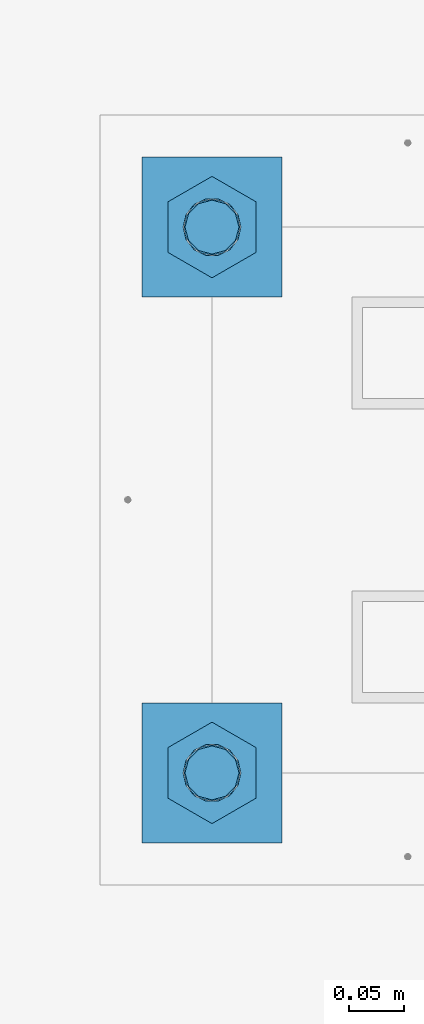
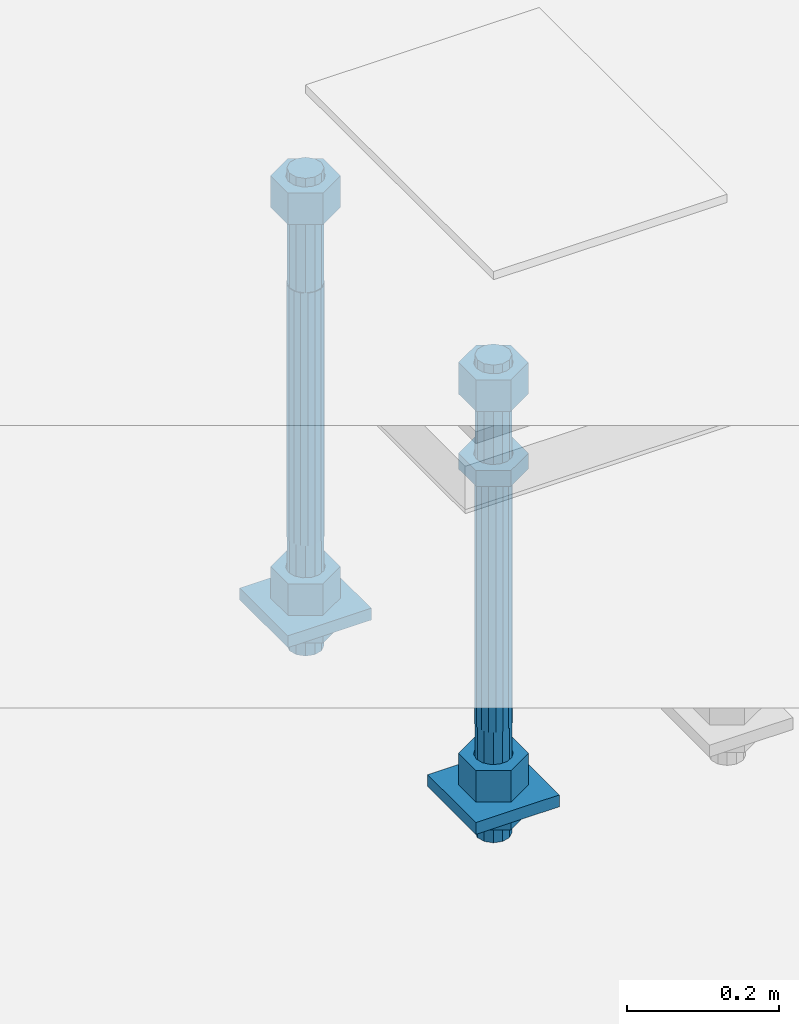
# One storey, part 2620 of 3843: 11 beams, 1 element without a shape of its own.
"""IFC2X3 building model written with IfcOpenShell, lengths in millimetres."""

from ifc_helpers import new_model, si_unit, frame, origin_with_axes, place, context, subcontext, project, spatial, faceted_brep, material, type_object, element, aggregate, save


model = new_model("IFC2X3")

# Units and contexts
model_context = context("Model", 3, precision=1e-05, world=origin_with_axes())
body_context = subcontext(model_context, "Body", "Model", "MODEL_VIEW")
ifc_project = project(units=[si_unit("LENGTHUNIT", "METRE", prefix="MILLI"), si_unit("AREAUNIT", "SQUARE_METRE"), si_unit("VOLUMEUNIT", "CUBIC_METRE"), si_unit("MASSUNIT", "GRAM", prefix="KILO"), si_unit("TIMEUNIT", "SECOND"), si_unit("PLANEANGLEUNIT", "RADIAN"), si_unit("SOLIDANGLEUNIT", "STERADIAN"), si_unit("THERMODYNAMICTEMPERATUREUNIT", "DEGREE_CELSIUS"), si_unit("LUMINOUSINTENSITYUNIT", "LUMEN")], contexts=[model_context])

# Site, building, storey
site_placement = place(None, origin_with_axes())
site = spatial("IfcSite", under=ifc_project, at=site_placement, CompositionType="ELEMENT")
building_placement = place(site_placement, origin_with_axes())
building = spatial("IfcBuilding", under=site, at=building_placement, Name="Undefined", CompositionType="ELEMENT")
storey_placement = place(building_placement, origin_with_axes())
storey = spatial("IfcBuildingStorey", under=building, at=storey_placement, Name="Undefined", CompositionType="ELEMENT", Elevation=0.0)

# Assembly, beams
assembly_placement = place(storey_placement, origin_with_axes())
assembly = element("IfcElementAssembly", 1, at=assembly_placement, inside=storey, Name="TEMPLATE", AssemblyPlace="NOTDEFINED", PredefinedType="RIGID_FRAME")
ifc_material_1 = material(Name="STEEL/A572-50")
beam_type_1 = type_object("IfcBeamType", PredefinedType="NOTDEFINED")
beam_1_placement = place(assembly_placement, frame((115862.100001526, 247.649999999994, 29244.925), z_axis=(0.0, -1.0, 0.0), x_axis=(1.0, 0.0, 0.0)))
beam_1 = element("IfcBeam", 2, at=beam_1_placement, type_object=beam_type_1, material=ifc_material_1, Name="WASHER_PLATE", context=body_context, shape_type="Brep", body=[
    faceted_brep([(0.0, 9.52500000000146, -63.5), (0.0, 9.52500000000146, 63.5), (127.0, 9.52500000000146, 63.5), (127.0, 9.52500000000146, -63.5), (0.0, -9.52500000000146, 63.5), (127.0, -9.52500000000146, 63.5), (0.0, -9.52500000000146, -63.5), (127.0, -9.52500000000146, -63.5)], [[[0, 1, 2, 3]], [[1, 4, 5, 2]], [[4, 6, 7, 5]], [[6, 0, 3, 7]], [[5, 7, 3, 2]], [[6, 4, 1, 0]]]),
])
beam_2_placement = place(assembly_placement, frame((115862.100001526, -247.649999999994, 29244.925), z_axis=(0.0, -1.0, 0.0), x_axis=(1.0, 0.0, 0.0)))
beam_2 = element("IfcBeam", 3, at=beam_2_placement, type_object=beam_type_1, material=ifc_material_1, Name="WASHER_PLATE", context=body_context, shape_type="Brep", body=[
    faceted_brep([(0.0, 9.52500000000146, -63.5), (0.0, 9.52500000000146, 63.5), (127.0, 9.52500000000146, 63.5), (127.0, 9.52500000000146, -63.5), (0.0, -9.52500000000146, 63.5), (127.0, -9.52500000000146, 63.5), (0.0, -9.52500000000146, -63.5), (127.0, -9.52500000000146, -63.5)], [[[0, 1, 2, 3]], [[1, 4, 5, 2]], [[4, 6, 7, 5]], [[6, 0, 3, 7]], [[5, 7, 3, 2]], [[6, 4, 1, 0]]]),
])
ifc_material_2 = material(Name="STEEL/A36")
beam_type_2 = type_object("IfcBeamType", Name="2_HALF_NUT", PredefinedType="NOTDEFINED")
beam_3_placement = place(assembly_placement, frame((115925.600001526, 247.649999999994, 29235.4), z_axis=(1.0, 0.0, 0.0), x_axis=(0.0, 0.0, -1.0)))
beam_3 = element("IfcBeam", 4, at=beam_3_placement, type_object=beam_type_2, material=ifc_material_2, Name="NUT", ObjectType="2_HALF_NUT", context=body_context, shape_type="Brep", body=[
    faceted_brep([(0.0, -46.0369987487793, 0.0), (0.0, -23.0184993743896, -39.869213104248), (25.4000000000015, -23.0184993743896, -39.869213104248), (25.4000000000015, -46.0369987487793, 0.0), (0.0, 23.0184993743896, -39.869213104248), (25.4000000000015, 23.0184993743896, -39.869213104248), (0.0, 46.0369987487793, 0.0), (25.4000000000015, 46.0369987487793, 0.0), (0.0, 23.0184993743896, 39.869213104248), (25.4000000000015, 23.0184993743896, 39.869213104248), (0.0, -23.0184993743896, 39.869213104248), (25.4000000000015, -23.0184993743896, 39.869213104248), (0.0, 0.0, 26.1940002441406), (0.0, 11.3650617044477, 23.5999013092805), (25.4000000000015, 11.3650617044477, 23.5999013092805), (25.4000000000015, 0.0, 26.1940002441406), (0.0, 20.4791109456419, 16.3316083006721), (25.4000000000015, 20.4791109456419, 16.3316083006721), (0.0, 25.5370200498292, 5.82867859874386), (25.4000000000015, 25.5370200498292, 5.82867859874386), (0.0, 25.5370200498292, -5.82867859874386), (25.4000000000015, 25.5370200498292, -5.82867859874386), (0.0, 20.4791109456419, -16.3316083006721), (25.4000000000015, 20.4791109456419, -16.3316083006721), (0.0, 11.3650617044477, -23.5999013092805), (25.4000000000015, 11.3650617044477, -23.5999013092805), (0.0, 0.0, -26.1940002441406), (25.4000000000015, 0.0, -26.1940002441406), (0.0, -11.3650617044477, -23.5999013092805), (25.4000000000015, -11.3650617044477, -23.5999013092805), (0.0, -20.4791109456419, -16.3316083006721), (25.4000000000015, -20.4791109456419, -16.3316083006721), (0.0, -25.5370200498292, -5.82867859874386), (25.4000000000015, -25.5370200498292, -5.82867859874386), (0.0, -25.5370200498292, 5.82867859874386), (25.4000000000015, -25.5370200498292, 5.82867859874386), (0.0, -20.4791109456419, 16.3316083006721), (25.4000000000015, -20.4791109456419, 16.3316083006721), (0.0, -11.3650617044477, 23.5999013092805), (25.4000000000015, -11.3650617044477, 23.5999013092805)], [[[0, 1, 2, 3]], [[1, 4, 5, 2]], [[4, 6, 7, 5]], [[6, 8, 9, 7]], [[8, 10, 11, 9]], [[10, 0, 3, 11]], [[12, 13, 14, 15]], [[13, 16, 17, 14]], [[16, 18, 19, 17]], [[18, 20, 21, 19]], [[20, 22, 23, 21]], [[22, 24, 25, 23]], [[24, 26, 27, 25]], [[26, 28, 29, 27]], [[28, 30, 31, 29]], [[30, 32, 33, 31]], [[32, 34, 35, 33]], [[34, 36, 37, 35]], [[36, 38, 39, 37]], [[38, 12, 15, 39]], [[5, 7, 9, 11, 3, 2], [17, 19, 21, 23, 25, 27, 29, 31, 33, 35, 37, 39, 15, 14]], [[10, 8, 6, 4, 1, 0], [38, 36, 34, 32, 30, 28, 26, 24, 22, 20, 18, 16, 13, 12]]]),
])
beam_4_placement = place(assembly_placement, frame((115925.600001526, -247.649999999994, 29787.85), z_axis=(1.0, 0.0, 0.0), x_axis=(0.0, 0.0, -1.0)))
beam_4 = element("IfcBeam", 5, at=beam_4_placement, type_object=beam_type_2, material=ifc_material_2, Name="NUT", ObjectType="2_HALF_NUT", context=body_context, shape_type="Brep", body=[
    faceted_brep([(0.0, -46.0369987487793, 0.0), (0.0, -23.0184993743896, -39.869213104248), (25.4000000000015, -23.0184993743896, -39.869213104248), (25.4000000000015, -46.0369987487793, 0.0), (0.0, 23.0184993743896, -39.869213104248), (25.4000000000015, 23.0184993743896, -39.869213104248), (0.0, 46.0369987487793, 0.0), (25.4000000000015, 46.0369987487793, 0.0), (0.0, 23.0184993743896, 39.869213104248), (25.4000000000015, 23.0184993743896, 39.869213104248), (0.0, -23.0184993743896, 39.869213104248), (25.4000000000015, -23.0184993743896, 39.869213104248), (0.0, 0.0, 26.1940002441406), (0.0, 11.3650617044477, 23.5999013092805), (25.4000000000015, 11.3650617044477, 23.5999013092805), (25.4000000000015, 0.0, 26.1940002441406), (0.0, 20.4791109456419, 16.3316083006721), (25.4000000000015, 20.4791109456419, 16.3316083006721), (0.0, 25.5370200498292, 5.82867859874386), (25.4000000000015, 25.5370200498292, 5.82867859874386), (0.0, 25.5370200498292, -5.82867859874386), (25.4000000000015, 25.5370200498292, -5.82867859874386), (0.0, 20.4791109456419, -16.3316083006721), (25.4000000000015, 20.4791109456419, -16.3316083006721), (0.0, 11.3650617044477, -23.5999013092805), (25.4000000000015, 11.3650617044477, -23.5999013092805), (0.0, 0.0, -26.1940002441406), (25.4000000000015, 0.0, -26.1940002441406), (0.0, -11.3650617044477, -23.5999013092805), (25.4000000000015, -11.3650617044477, -23.5999013092805), (0.0, -20.4791109456419, -16.3316083006721), (25.4000000000015, -20.4791109456419, -16.3316083006721), (0.0, -25.5370200498292, -5.82867859874386), (25.4000000000015, -25.5370200498292, -5.82867859874386), (0.0, -25.5370200498292, 5.82867859874386), (25.4000000000015, -25.5370200498292, 5.82867859874386), (0.0, -20.4791109456419, 16.3316083006721), (25.4000000000015, -20.4791109456419, 16.3316083006721), (0.0, -11.3650617044477, 23.5999013092805), (25.4000000000015, -11.3650617044477, 23.5999013092805)], [[[0, 1, 2, 3]], [[1, 4, 5, 2]], [[4, 6, 7, 5]], [[6, 8, 9, 7]], [[8, 10, 11, 9]], [[10, 0, 3, 11]], [[12, 13, 14, 15]], [[13, 16, 17, 14]], [[16, 18, 19, 17]], [[18, 20, 21, 19]], [[20, 22, 23, 21]], [[22, 24, 25, 23]], [[24, 26, 27, 25]], [[26, 28, 29, 27]], [[28, 30, 31, 29]], [[30, 32, 33, 31]], [[32, 34, 35, 33]], [[34, 36, 37, 35]], [[36, 38, 39, 37]], [[38, 12, 15, 39]], [[5, 7, 9, 11, 3, 2], [17, 19, 21, 23, 25, 27, 29, 31, 33, 35, 37, 39, 15, 14]], [[10, 8, 6, 4, 1, 0], [38, 36, 34, 32, 30, 28, 26, 24, 22, 20, 18, 16, 13, 12]]]),
])
beam_5_placement = place(assembly_placement, frame((115925.600001526, -247.649999999994, 29235.4), z_axis=(1.0, 0.0, 0.0), x_axis=(0.0, 0.0, -1.0)))
beam_5 = element("IfcBeam", 6, at=beam_5_placement, type_object=beam_type_2, material=ifc_material_2, Name="NUT", ObjectType="2_HALF_NUT", context=body_context, shape_type="Brep", body=[
    faceted_brep([(0.0, -46.0369987487793, 0.0), (0.0, -23.0184993743896, -39.869213104248), (25.4000000000015, -23.0184993743896, -39.869213104248), (25.4000000000015, -46.0369987487793, 0.0), (0.0, 23.0184993743896, -39.869213104248), (25.4000000000015, 23.0184993743896, -39.869213104248), (0.0, 46.0369987487793, 0.0), (25.4000000000015, 46.0369987487793, 0.0), (0.0, 23.0184993743896, 39.869213104248), (25.4000000000015, 23.0184993743896, 39.869213104248), (0.0, -23.0184993743896, 39.869213104248), (25.4000000000015, -23.0184993743896, 39.869213104248), (0.0, 0.0, 26.1940002441406), (0.0, 11.3650617044477, 23.5999013092805), (25.4000000000015, 11.3650617044477, 23.5999013092805), (25.4000000000015, 0.0, 26.1940002441406), (0.0, 20.4791109456419, 16.3316083006721), (25.4000000000015, 20.4791109456419, 16.3316083006721), (0.0, 25.5370200498292, 5.82867859874386), (25.4000000000015, 25.5370200498292, 5.82867859874386), (0.0, 25.5370200498292, -5.82867859874386), (25.4000000000015, 25.5370200498292, -5.82867859874386), (0.0, 20.4791109456419, -16.3316083006721), (25.4000000000015, 20.4791109456419, -16.3316083006721), (0.0, 11.3650617044477, -23.5999013092805), (25.4000000000015, 11.3650617044477, -23.5999013092805), (0.0, 0.0, -26.1940002441406), (25.4000000000015, 0.0, -26.1940002441406), (0.0, -11.3650617044477, -23.5999013092805), (25.4000000000015, -11.3650617044477, -23.5999013092805), (0.0, -20.4791109456419, -16.3316083006721), (25.4000000000015, -20.4791109456419, -16.3316083006721), (0.0, -25.5370200498292, -5.82867859874386), (25.4000000000015, -25.5370200498292, -5.82867859874386), (0.0, -25.5370200498292, 5.82867859874386), (25.4000000000015, -25.5370200498292, 5.82867859874386), (0.0, -20.4791109456419, 16.3316083006721), (25.4000000000015, -20.4791109456419, 16.3316083006721), (0.0, -11.3650617044477, 23.5999013092805), (25.4000000000015, -11.3650617044477, 23.5999013092805)], [[[0, 1, 2, 3]], [[1, 4, 5, 2]], [[4, 6, 7, 5]], [[6, 8, 9, 7]], [[8, 10, 11, 9]], [[10, 0, 3, 11]], [[12, 13, 14, 15]], [[13, 16, 17, 14]], [[16, 18, 19, 17]], [[18, 20, 21, 19]], [[20, 22, 23, 21]], [[22, 24, 25, 23]], [[24, 26, 27, 25]], [[26, 28, 29, 27]], [[28, 30, 31, 29]], [[30, 32, 33, 31]], [[32, 34, 35, 33]], [[34, 36, 37, 35]], [[36, 38, 39, 37]], [[38, 12, 15, 39]], [[5, 7, 9, 11, 3, 2], [17, 19, 21, 23, 25, 27, 29, 31, 33, 35, 37, 39, 15, 14]], [[10, 8, 6, 4, 1, 0], [38, 36, 34, 32, 30, 28, 26, 24, 22, 20, 18, 16, 13, 12]]]),
])
beam_type_3 = type_object("IfcBeamType", Name="2_HEAVY_HEX_NUT", PredefinedType="NOTDEFINED")
beam_6_placement = place(assembly_placement, frame((115925.600001526, 247.649999999994, 29933.9), z_axis=(1.0, 0.0, 0.0), x_axis=(0.0, 0.0, -1.0)))
beam_6 = element("IfcBeam", 7, at=beam_6_placement, type_object=beam_type_3, material=ifc_material_2, Name="NUT", ObjectType="2_HEAVY_HEX_NUT", context=body_context, shape_type="Brep", body=[
    faceted_brep([(0.0, -46.0369987487793, 0.0), (0.0, -23.0184993743896, -39.869213104248), (50.7999999999993, -23.0184993743896, -39.869213104248), (50.7999999999993, -46.0369987487793, 0.0), (0.0, 23.0184993743896, -39.869213104248), (50.7999999999993, 23.0184993743896, -39.869213104248), (0.0, 46.0369987487793, 0.0), (50.7999999999993, 46.0369987487793, 0.0), (0.0, 23.0184993743896, 39.869213104248), (50.7999999999993, 23.0184993743896, 39.869213104248), (0.0, -23.0184993743896, 39.869213104248), (50.7999999999993, -23.0184993743896, 39.869213104248), (0.0, 0.0, 26.1940002441406), (0.0, 11.3650617044477, 23.5999013092805), (50.7999999999993, 11.3650617044477, 23.5999013092805), (50.7999999999993, 0.0, 26.1940002441406), (0.0, 20.4791109456419, 16.3316083006721), (50.7999999999993, 20.4791109456419, 16.3316083006721), (0.0, 25.5370200498292, 5.82867859874386), (50.7999999999993, 25.5370200498292, 5.82867859874386), (0.0, 25.5370200498292, -5.82867859874386), (50.7999999999993, 25.5370200498292, -5.82867859874386), (0.0, 20.4791109456419, -16.3316083006721), (50.7999999999993, 20.4791109456419, -16.3316083006721), (0.0, 11.3650617044477, -23.5999013092805), (50.7999999999993, 11.3650617044477, -23.5999013092805), (0.0, 0.0, -26.1940002441406), (50.7999999999993, 0.0, -26.1940002441406), (0.0, -11.3650617044477, -23.5999013092805), (50.7999999999993, -11.3650617044477, -23.5999013092805), (0.0, -20.4791109456419, -16.3316083006721), (50.7999999999993, -20.4791109456419, -16.3316083006721), (0.0, -25.5370200498292, -5.82867859874386), (50.7999999999993, -25.5370200498292, -5.82867859874386), (0.0, -25.5370200498292, 5.82867859874386), (50.7999999999993, -25.5370200498292, 5.82867859874386), (0.0, -20.4791109456419, 16.3316083006721), (50.7999999999993, -20.4791109456419, 16.3316083006721), (0.0, -11.3650617044477, 23.5999013092805), (50.7999999999993, -11.3650617044477, 23.5999013092805)], [[[0, 1, 2, 3]], [[1, 4, 5, 2]], [[4, 6, 7, 5]], [[6, 8, 9, 7]], [[8, 10, 11, 9]], [[10, 0, 3, 11]], [[12, 13, 14, 15]], [[13, 16, 17, 14]], [[16, 18, 19, 17]], [[18, 20, 21, 19]], [[20, 22, 23, 21]], [[22, 24, 25, 23]], [[24, 26, 27, 25]], [[26, 28, 29, 27]], [[28, 30, 31, 29]], [[30, 32, 33, 31]], [[32, 34, 35, 33]], [[34, 36, 37, 35]], [[36, 38, 39, 37]], [[38, 12, 15, 39]], [[5, 7, 9, 11, 3, 2], [17, 19, 21, 23, 25, 27, 29, 31, 33, 35, 37, 39, 15, 14]], [[10, 8, 6, 4, 1, 0], [38, 36, 34, 32, 30, 28, 26, 24, 22, 20, 18, 16, 13, 12]]]),
])
beam_7_placement = place(assembly_placement, frame((115925.600001526, 247.649999999994, 29305.25), z_axis=(1.0, 0.0, 0.0), x_axis=(0.0, 0.0, -1.0)))
beam_7 = element("IfcBeam", 8, at=beam_7_placement, type_object=beam_type_3, material=ifc_material_2, Name="NUT", ObjectType="2_HEAVY_HEX_NUT", context=body_context, shape_type="Brep", body=[
    faceted_brep([(0.0, -46.0369987487793, 0.0), (0.0, -23.0184993743896, -39.869213104248), (50.7999999999993, -23.0184993743896, -39.869213104248), (50.7999999999993, -46.0369987487793, 0.0), (0.0, 23.0184993743896, -39.869213104248), (50.7999999999993, 23.0184993743896, -39.869213104248), (0.0, 46.0369987487793, 0.0), (50.7999999999993, 46.0369987487793, 0.0), (0.0, 23.0184993743896, 39.869213104248), (50.7999999999993, 23.0184993743896, 39.869213104248), (0.0, -23.0184993743896, 39.869213104248), (50.7999999999993, -23.0184993743896, 39.869213104248), (0.0, 0.0, 26.1940002441406), (0.0, 11.3650617044477, 23.5999013092805), (50.7999999999993, 11.3650617044477, 23.5999013092805), (50.7999999999993, 0.0, 26.1940002441406), (0.0, 20.4791109456419, 16.3316083006721), (50.7999999999993, 20.4791109456419, 16.3316083006721), (0.0, 25.5370200498292, 5.82867859874386), (50.7999999999993, 25.5370200498292, 5.82867859874386), (0.0, 25.5370200498292, -5.82867859874386), (50.7999999999993, 25.5370200498292, -5.82867859874386), (0.0, 20.4791109456419, -16.3316083006721), (50.7999999999993, 20.4791109456419, -16.3316083006721), (0.0, 11.3650617044477, -23.5999013092805), (50.7999999999993, 11.3650617044477, -23.5999013092805), (0.0, 0.0, -26.1940002441406), (50.7999999999993, 0.0, -26.1940002441406), (0.0, -11.3650617044477, -23.5999013092805), (50.7999999999993, -11.3650617044477, -23.5999013092805), (0.0, -20.4791109456419, -16.3316083006721), (50.7999999999993, -20.4791109456419, -16.3316083006721), (0.0, -25.5370200498292, -5.82867859874386), (50.7999999999993, -25.5370200498292, -5.82867859874386), (0.0, -25.5370200498292, 5.82867859874386), (50.7999999999993, -25.5370200498292, 5.82867859874386), (0.0, -20.4791109456419, 16.3316083006721), (50.7999999999993, -20.4791109456419, 16.3316083006721), (0.0, -11.3650617044477, 23.5999013092805), (50.7999999999993, -11.3650617044477, 23.5999013092805)], [[[0, 1, 2, 3]], [[1, 4, 5, 2]], [[4, 6, 7, 5]], [[6, 8, 9, 7]], [[8, 10, 11, 9]], [[10, 0, 3, 11]], [[12, 13, 14, 15]], [[13, 16, 17, 14]], [[16, 18, 19, 17]], [[18, 20, 21, 19]], [[20, 22, 23, 21]], [[22, 24, 25, 23]], [[24, 26, 27, 25]], [[26, 28, 29, 27]], [[28, 30, 31, 29]], [[30, 32, 33, 31]], [[32, 34, 35, 33]], [[34, 36, 37, 35]], [[36, 38, 39, 37]], [[38, 12, 15, 39]], [[5, 7, 9, 11, 3, 2], [17, 19, 21, 23, 25, 27, 29, 31, 33, 35, 37, 39, 15, 14]], [[10, 8, 6, 4, 1, 0], [38, 36, 34, 32, 30, 28, 26, 24, 22, 20, 18, 16, 13, 12]]]),
])
beam_8_placement = place(assembly_placement, frame((115925.600001526, -247.649999999994, 29933.9), z_axis=(1.0, 0.0, 0.0), x_axis=(0.0, 0.0, -1.0)))
beam_8 = element("IfcBeam", 9, at=beam_8_placement, type_object=beam_type_3, material=ifc_material_2, Name="NUT", ObjectType="2_HEAVY_HEX_NUT", context=body_context, shape_type="Brep", body=[
    faceted_brep([(0.0, -46.0369987487793, 0.0), (0.0, -23.0184993743896, -39.869213104248), (50.7999999999993, -23.0184993743896, -39.869213104248), (50.7999999999993, -46.0369987487793, 0.0), (0.0, 23.0184993743896, -39.869213104248), (50.7999999999993, 23.0184993743896, -39.869213104248), (0.0, 46.0369987487793, 0.0), (50.7999999999993, 46.0369987487793, 0.0), (0.0, 23.0184993743896, 39.869213104248), (50.7999999999993, 23.0184993743896, 39.869213104248), (0.0, -23.0184993743896, 39.869213104248), (50.7999999999993, -23.0184993743896, 39.869213104248), (0.0, 0.0, 26.1940002441406), (0.0, 11.3650617044477, 23.5999013092805), (50.7999999999993, 11.3650617044477, 23.5999013092805), (50.7999999999993, 0.0, 26.1940002441406), (0.0, 20.4791109456419, 16.3316083006721), (50.7999999999993, 20.4791109456419, 16.3316083006721), (0.0, 25.5370200498292, 5.82867859874386), (50.7999999999993, 25.5370200498292, 5.82867859874386), (0.0, 25.5370200498292, -5.82867859874386), (50.7999999999993, 25.5370200498292, -5.82867859874386), (0.0, 20.4791109456419, -16.3316083006721), (50.7999999999993, 20.4791109456419, -16.3316083006721), (0.0, 11.3650617044477, -23.5999013092805), (50.7999999999993, 11.3650617044477, -23.5999013092805), (0.0, 0.0, -26.1940002441406), (50.7999999999993, 0.0, -26.1940002441406), (0.0, -11.3650617044477, -23.5999013092805), (50.7999999999993, -11.3650617044477, -23.5999013092805), (0.0, -20.4791109456419, -16.3316083006721), (50.7999999999993, -20.4791109456419, -16.3316083006721), (0.0, -25.5370200498292, -5.82867859874386), (50.7999999999993, -25.5370200498292, -5.82867859874386), (0.0, -25.5370200498292, 5.82867859874386), (50.7999999999993, -25.5370200498292, 5.82867859874386), (0.0, -20.4791109456419, 16.3316083006721), (50.7999999999993, -20.4791109456419, 16.3316083006721), (0.0, -11.3650617044477, 23.5999013092805), (50.7999999999993, -11.3650617044477, 23.5999013092805)], [[[0, 1, 2, 3]], [[1, 4, 5, 2]], [[4, 6, 7, 5]], [[6, 8, 9, 7]], [[8, 10, 11, 9]], [[10, 0, 3, 11]], [[12, 13, 14, 15]], [[13, 16, 17, 14]], [[16, 18, 19, 17]], [[18, 20, 21, 19]], [[20, 22, 23, 21]], [[22, 24, 25, 23]], [[24, 26, 27, 25]], [[26, 28, 29, 27]], [[28, 30, 31, 29]], [[30, 32, 33, 31]], [[32, 34, 35, 33]], [[34, 36, 37, 35]], [[36, 38, 39, 37]], [[38, 12, 15, 39]], [[5, 7, 9, 11, 3, 2], [17, 19, 21, 23, 25, 27, 29, 31, 33, 35, 37, 39, 15, 14]], [[10, 8, 6, 4, 1, 0], [38, 36, 34, 32, 30, 28, 26, 24, 22, 20, 18, 16, 13, 12]]]),
])
beam_9_placement = place(assembly_placement, frame((115925.600001526, -247.649999999994, 29305.25), z_axis=(1.0, 0.0, 0.0), x_axis=(0.0, 0.0, -1.0)))
beam_9 = element("IfcBeam", 10, at=beam_9_placement, type_object=beam_type_3, material=ifc_material_2, Name="NUT", ObjectType="2_HEAVY_HEX_NUT", context=body_context, shape_type="Brep", body=[
    faceted_brep([(0.0, -46.0369987487793, 0.0), (0.0, -23.0184993743896, -39.869213104248), (50.7999999999993, -23.0184993743896, -39.869213104248), (50.7999999999993, -46.0369987487793, 0.0), (0.0, 23.0184993743896, -39.869213104248), (50.7999999999993, 23.0184993743896, -39.869213104248), (0.0, 46.0369987487793, 0.0), (50.7999999999993, 46.0369987487793, 0.0), (0.0, 23.0184993743896, 39.869213104248), (50.7999999999993, 23.0184993743896, 39.869213104248), (0.0, -23.0184993743896, 39.869213104248), (50.7999999999993, -23.0184993743896, 39.869213104248), (0.0, 0.0, 26.1940002441406), (0.0, 11.3650617044477, 23.5999013092805), (50.7999999999993, 11.3650617044477, 23.5999013092805), (50.7999999999993, 0.0, 26.1940002441406), (0.0, 20.4791109456419, 16.3316083006721), (50.7999999999993, 20.4791109456419, 16.3316083006721), (0.0, 25.5370200498292, 5.82867859874386), (50.7999999999993, 25.5370200498292, 5.82867859874386), (0.0, 25.5370200498292, -5.82867859874386), (50.7999999999993, 25.5370200498292, -5.82867859874386), (0.0, 20.4791109456419, -16.3316083006721), (50.7999999999993, 20.4791109456419, -16.3316083006721), (0.0, 11.3650617044477, -23.5999013092805), (50.7999999999993, 11.3650617044477, -23.5999013092805), (0.0, 0.0, -26.1940002441406), (50.7999999999993, 0.0, -26.1940002441406), (0.0, -11.3650617044477, -23.5999013092805), (50.7999999999993, -11.3650617044477, -23.5999013092805), (0.0, -20.4791109456419, -16.3316083006721), (50.7999999999993, -20.4791109456419, -16.3316083006721), (0.0, -25.5370200498292, -5.82867859874386), (50.7999999999993, -25.5370200498292, -5.82867859874386), (0.0, -25.5370200498292, 5.82867859874386), (50.7999999999993, -25.5370200498292, 5.82867859874386), (0.0, -20.4791109456419, 16.3316083006721), (50.7999999999993, -20.4791109456419, 16.3316083006721), (0.0, -11.3650617044477, 23.5999013092805), (50.7999999999993, -11.3650617044477, 23.5999013092805)], [[[0, 1, 2, 3]], [[1, 4, 5, 2]], [[4, 6, 7, 5]], [[6, 8, 9, 7]], [[8, 10, 11, 9]], [[10, 0, 3, 11]], [[12, 13, 14, 15]], [[13, 16, 17, 14]], [[16, 18, 19, 17]], [[18, 20, 21, 19]], [[20, 22, 23, 21]], [[22, 24, 25, 23]], [[24, 26, 27, 25]], [[26, 28, 29, 27]], [[28, 30, 31, 29]], [[30, 32, 33, 31]], [[32, 34, 35, 33]], [[34, 36, 37, 35]], [[36, 38, 39, 37]], [[38, 12, 15, 39]], [[5, 7, 9, 11, 3, 2], [17, 19, 21, 23, 25, 27, 29, 31, 33, 35, 37, 39, 15, 14]], [[10, 8, 6, 4, 1, 0], [38, 36, 34, 32, 30, 28, 26, 24, 22, 20, 18, 16, 13, 12]]]),
])
ifc_material_3 = material()
beam_type_4 = type_object("IfcBeamType", PredefinedType="NOTDEFINED")
beam_10_placement = place(assembly_placement, frame((115925.600001526, 247.649999999994, 29762.45), z_axis=(1.0, 0.0, 0.0), x_axis=(0.0, 0.0, -1.0)))
beam_10 = element("IfcBeam", 11, at=beam_10_placement, type_object=beam_type_4, material=ifc_material_3, Name="ANCHOR_ROD", context=body_context, shape_type="Brep", body=[
    faceted_brep([(-184.150000000001, -21.217622392709, 12.25), (-184.150000000001, -12.2499999999854, 21.2176223927163), (-184.150000000001, 1.45519152283669e-11, 24.5), (-184.150000000001, 12.2500000000146, 21.2176223927163), (-184.150000000001, 21.2176223927381, 12.25), (-184.150000000001, 24.5000000000146, 0.0), (-184.150000000001, 21.2176223927381, -12.25), (-184.150000000001, 12.2500000000146, -21.2176223927163), (-184.150000000001, 1.45519152283669e-11, -24.5), (-184.150000000001, -12.2499999999854, -21.2176223927163), (-184.150000000001, -21.217622392709, -12.25), (-184.150000000001, -24.4999999999854, 0.0), (0.0, 24.5000000000146, 0.0), (0.0, 21.2176223927381, -12.25), (0.0, 12.2500000000146, -21.2176223927163), (0.0, 1.45519152283669e-11, -24.5), (0.0, -12.2499999999854, -21.2176223927163), (0.0, -21.217622392709, -12.25), (0.0, -24.4999999999854, 0.0), (0.0, -21.217622392709, 12.25), (0.0, -12.2499999999854, 21.2176223927163), (0.0, 1.45519152283669e-11, 24.5), (0.0, 12.2500000000146, 21.2176223927163), (0.0, 21.2176223927381, 12.25), (0.0, -23.4665401257807, 9.72015918207035), (0.0, -17.9605122421344, 17.9605122421417), (0.0, -9.72015918207762, 23.466540125788), (0.0, 0.0, 25.4000000000015), (0.0, 9.72015918207762, 23.466540125788), (0.0, 17.9605122421344, 17.9605122421417), (0.0, 23.4665401257807, 9.72015918207035), (0.0, 25.3999996185303, 0.0), (0.0, 23.4665401257807, -9.72015918207035), (0.0, 17.9605122421344, -17.9605122421417), (0.0, 9.72015918207762, -23.466540125788), (0.0, 0.0, -25.4000000000015), (0.0, -9.72015918207762, -23.466540125788), (0.0, -17.9605122421344, -17.9605122421417), (0.0, -23.4665401257807, -9.72015918207035), (0.0, -25.3999996185303, 0.0), (406.399999999998, -25.3999999999942, 0.0), (406.399999999998, -23.4665401257807, 9.72015918207035), (406.399999999998, -17.9605122421344, 17.9605122421417), (406.399999999998, -9.72015918207762, 23.466540125788), (406.399999999998, 0.0, 25.4000000000015), (406.399999999998, 9.72015918207762, 23.466540125788), (406.399999999998, 17.9605122421344, 17.9605122421417), (406.399999999998, 23.4665401257807, 9.72015918207035), (406.399999999998, 25.3999999999942, 0.0), (406.399999999998, 23.4665401257807, -9.72015918207035), (406.399999999998, 17.9605122421344, -17.9605122421417), (406.399999999998, 9.72015918207762, -23.466540125788), (406.399999999998, 0.0, -25.4000000000015), (406.399999999998, -9.72015918207762, -23.466540125788), (406.399999999998, -17.9605122421344, -17.9605122421417), (406.399999999998, -23.4665401257807, -9.72015918207035), (406.399999999998, -12.2499999999854, 21.2176223927163), (406.399999999998, 1.45519152283669e-11, 24.5), (406.399999999998, 12.2500000000146, 21.2176223927163), (406.399999999998, 21.2176223927381, 12.25), (406.399999999998, 24.5000000000146, 0.0), (406.399999999998, 21.2176223927381, -12.25), (406.399999999998, 12.2500000000146, -21.2176223927163), (406.399999999998, 1.45519152283669e-11, -24.5), (406.399999999998, -12.2499999999854, -21.2176223927163), (406.399999999998, -21.217622392709, -12.25), (406.399999999998, -24.4999999999854, 0.0), (406.399999999998, -21.217622392709, 12.25), (584.200000000001, -12.2499999999854, -21.2176223927163), (584.200000000001, 1.45519152283669e-11, -24.5), (584.200000000001, 12.2500000000146, -21.2176223927163), (584.200000000001, 21.2176223927381, -12.25), (584.200000000001, 24.5000000000146, 0.0), (584.200000000001, 21.2176223927381, 12.25), (584.200000000001, 12.2500000000146, 21.2176223927163), (584.200000000001, 1.45519152283669e-11, 24.5), (584.200000000001, -12.2499999999854, 21.2176223927163), (584.200000000001, -21.217622392709, 12.25), (584.200000000001, -24.4999999999854, 0.0), (584.200000000001, -21.217622392709, -12.25)], [[[0, 1, 2, 3, 4, 5, 6, 7, 8, 9, 10, 11]], [[6, 5, 12, 13]], [[7, 6, 13, 14]], [[8, 7, 14, 15]], [[9, 8, 15, 16]], [[10, 9, 16, 17]], [[11, 10, 17, 18]], [[0, 11, 18, 19]], [[1, 0, 19, 20]], [[2, 1, 20, 21]], [[3, 2, 21, 22]], [[4, 3, 22, 23]], [[5, 4, 23, 12]], [[24, 25, 26, 27, 28, 29, 30, 31, 32, 33, 34, 35, 36, 37, 38, 39], [22, 21, 20, 19, 18, 17, 16, 15, 14, 13, 12, 23]], [[24, 39, 40, 41]], [[25, 24, 41, 42]], [[26, 25, 42, 43]], [[27, 26, 43, 44]], [[28, 27, 44, 45]], [[29, 28, 45, 46]], [[30, 29, 46, 47]], [[31, 30, 47, 48]], [[32, 31, 48, 49]], [[33, 32, 49, 50]], [[34, 33, 50, 51]], [[35, 34, 51, 52]], [[36, 35, 52, 53]], [[37, 36, 53, 54]], [[38, 37, 54, 55]], [[39, 38, 55, 40]], [[54, 53, 52, 51, 50, 49, 48, 47, 46, 45, 44, 43, 42, 41, 40, 55], [56, 57, 58, 59, 60, 61, 62, 63, 64, 65, 66, 67]], [[68, 69, 70, 71, 72, 73, 74, 75, 76, 77, 78, 79]], [[76, 75, 57, 56]], [[77, 76, 56, 67]], [[78, 77, 67, 66]], [[79, 78, 66, 65]], [[68, 79, 65, 64]], [[69, 68, 64, 63]], [[70, 69, 63, 62]], [[71, 70, 62, 61]], [[72, 71, 61, 60]], [[73, 72, 60, 59]], [[74, 73, 59, 58]], [[75, 74, 58, 57]]]),
])
beam_11_placement = place(assembly_placement, frame((115925.600001526, -247.649999999994, 29762.45), z_axis=(1.0, 0.0, 0.0), x_axis=(0.0, 0.0, -1.0)))
beam_11 = element("IfcBeam", 12, at=beam_11_placement, type_object=beam_type_4, material=ifc_material_3, Name="ANCHOR_ROD", context=body_context, shape_type="Brep", body=[
    faceted_brep([(-184.150000000001, -21.217622392709, 12.25), (-184.150000000001, -12.2499999999854, 21.2176223927163), (-184.150000000001, 1.45519152283669e-11, 24.5), (-184.150000000001, 12.2500000000146, 21.2176223927163), (-184.150000000001, 21.2176223927381, 12.25), (-184.150000000001, 24.5000000000146, 0.0), (-184.150000000001, 21.2176223927381, -12.25), (-184.150000000001, 12.2500000000146, -21.2176223927163), (-184.150000000001, 1.45519152283669e-11, -24.5), (-184.150000000001, -12.2499999999854, -21.2176223927163), (-184.150000000001, -21.217622392709, -12.25), (-184.150000000001, -24.4999999999854, 0.0), (0.0, 24.5000000000146, 0.0), (0.0, 21.2176223927381, -12.25), (0.0, 12.2500000000146, -21.2176223927163), (0.0, 1.45519152283669e-11, -24.5), (0.0, -12.2499999999854, -21.2176223927163), (0.0, -21.217622392709, -12.25), (0.0, -24.4999999999854, 0.0), (0.0, -21.217622392709, 12.25), (0.0, -12.2499999999854, 21.2176223927163), (0.0, 1.45519152283669e-11, 24.5), (0.0, 12.2500000000146, 21.2176223927163), (0.0, 21.2176223927381, 12.25), (0.0, -23.4665401257807, 9.72015918207035), (0.0, -17.9605122421344, 17.9605122421417), (0.0, -9.72015918207762, 23.466540125788), (0.0, 0.0, 25.4000000000015), (0.0, 9.72015918207762, 23.466540125788), (0.0, 17.9605122421344, 17.9605122421417), (0.0, 23.4665401257807, 9.72015918207035), (0.0, 25.3999996185303, 0.0), (0.0, 23.4665401257807, -9.72015918207035), (0.0, 17.9605122421344, -17.9605122421417), (0.0, 9.72015918207762, -23.466540125788), (0.0, 0.0, -25.4000000000015), (0.0, -9.72015918207762, -23.466540125788), (0.0, -17.9605122421344, -17.9605122421417), (0.0, -23.4665401257807, -9.72015918207035), (0.0, -25.3999996185303, 0.0), (406.399999999998, -25.3999999999942, 0.0), (406.399999999998, -23.4665401257807, 9.72015918207035), (406.399999999998, -17.9605122421344, 17.9605122421417), (406.399999999998, -9.72015918207762, 23.466540125788), (406.399999999998, 0.0, 25.4000000000015), (406.399999999998, 9.72015918207762, 23.466540125788), (406.399999999998, 17.9605122421344, 17.9605122421417), (406.399999999998, 23.4665401257807, 9.72015918207035), (406.399999999998, 25.3999999999942, 0.0), (406.399999999998, 23.4665401257807, -9.72015918207035), (406.399999999998, 17.9605122421344, -17.9605122421417), (406.399999999998, 9.72015918207762, -23.466540125788), (406.399999999998, 0.0, -25.4000000000015), (406.399999999998, -9.72015918207762, -23.466540125788), (406.399999999998, -17.9605122421344, -17.9605122421417), (406.399999999998, -23.4665401257807, -9.72015918207035), (406.399999999998, -12.2499999999854, 21.2176223927163), (406.399999999998, 1.45519152283669e-11, 24.5), (406.399999999998, 12.2500000000146, 21.2176223927163), (406.399999999998, 21.2176223927381, 12.25), (406.399999999998, 24.5000000000146, 0.0), (406.399999999998, 21.2176223927381, -12.25), (406.399999999998, 12.2500000000146, -21.2176223927163), (406.399999999998, 1.45519152283669e-11, -24.5), (406.399999999998, -12.2499999999854, -21.2176223927163), (406.399999999998, -21.217622392709, -12.25), (406.399999999998, -24.4999999999854, 0.0), (406.399999999998, -21.217622392709, 12.25), (584.200000000001, -12.2499999999854, -21.2176223927163), (584.200000000001, 1.45519152283669e-11, -24.5), (584.200000000001, 12.2500000000146, -21.2176223927163), (584.200000000001, 21.2176223927381, -12.25), (584.200000000001, 24.5000000000146, 0.0), (584.200000000001, 21.2176223927381, 12.25), (584.200000000001, 12.2500000000146, 21.2176223927163), (584.200000000001, 1.45519152283669e-11, 24.5), (584.200000000001, -12.2499999999854, 21.2176223927163), (584.200000000001, -21.217622392709, 12.25), (584.200000000001, -24.4999999999854, 0.0), (584.200000000001, -21.217622392709, -12.25)], [[[0, 1, 2, 3, 4, 5, 6, 7, 8, 9, 10, 11]], [[6, 5, 12, 13]], [[7, 6, 13, 14]], [[8, 7, 14, 15]], [[9, 8, 15, 16]], [[10, 9, 16, 17]], [[11, 10, 17, 18]], [[0, 11, 18, 19]], [[1, 0, 19, 20]], [[2, 1, 20, 21]], [[3, 2, 21, 22]], [[4, 3, 22, 23]], [[5, 4, 23, 12]], [[24, 25, 26, 27, 28, 29, 30, 31, 32, 33, 34, 35, 36, 37, 38, 39], [22, 21, 20, 19, 18, 17, 16, 15, 14, 13, 12, 23]], [[24, 39, 40, 41]], [[25, 24, 41, 42]], [[26, 25, 42, 43]], [[27, 26, 43, 44]], [[28, 27, 44, 45]], [[29, 28, 45, 46]], [[30, 29, 46, 47]], [[31, 30, 47, 48]], [[32, 31, 48, 49]], [[33, 32, 49, 50]], [[34, 33, 50, 51]], [[35, 34, 51, 52]], [[36, 35, 52, 53]], [[37, 36, 53, 54]], [[38, 37, 54, 55]], [[39, 38, 55, 40]], [[54, 53, 52, 51, 50, 49, 48, 47, 46, 45, 44, 43, 42, 41, 40, 55], [56, 57, 58, 59, 60, 61, 62, 63, 64, 65, 66, 67]], [[68, 69, 70, 71, 72, 73, 74, 75, 76, 77, 78, 79]], [[76, 75, 57, 56]], [[77, 76, 56, 67]], [[78, 77, 67, 66]], [[79, 78, 66, 65]], [[68, 79, 65, 64]], [[69, 68, 64, 63]], [[70, 69, 63, 62]], [[71, 70, 62, 61]], [[72, 71, 61, 60]], [[73, 72, 60, 59]], [[74, 73, 59, 58]], [[75, 74, 58, 57]]]),
])
aggregate(assembly, [beam_6, beam_7, beam_3, beam_1, beam_10, beam_4, beam_8, beam_9, beam_5, beam_2, beam_11])

save(model, "model.ifc")
